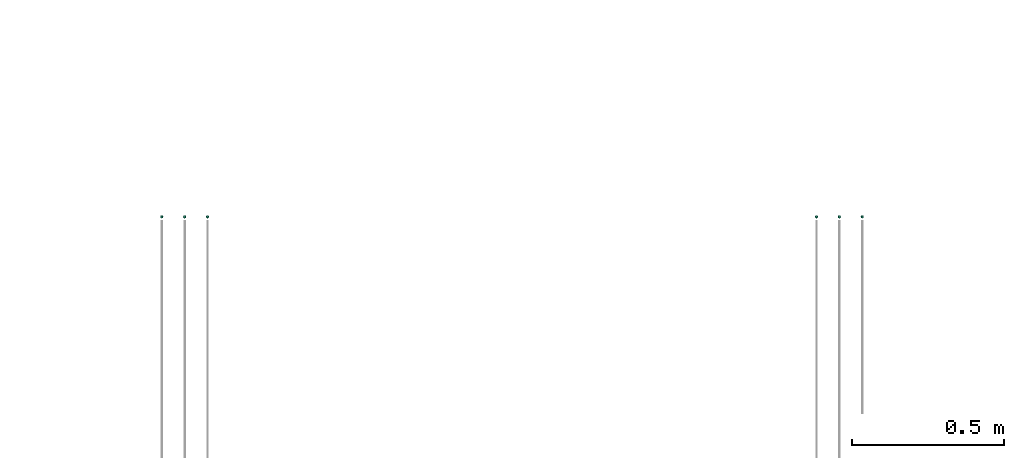
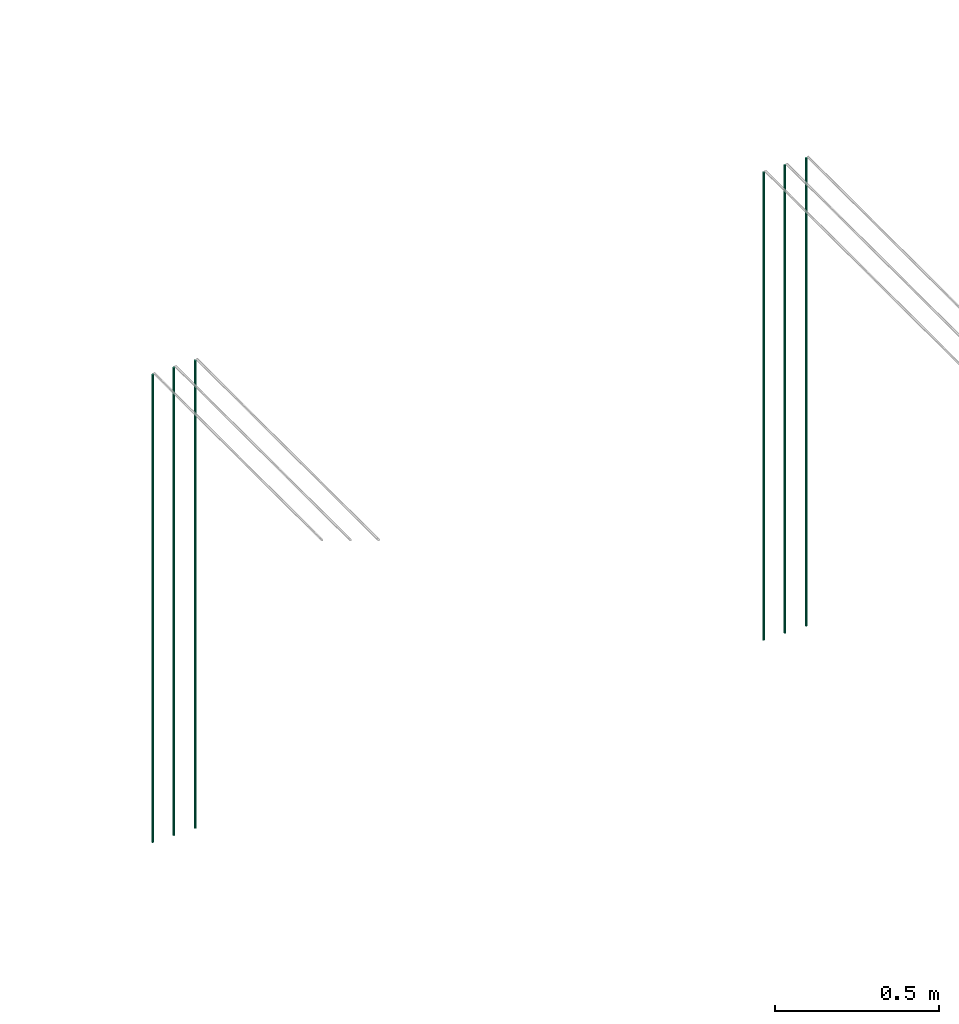
# One storey, part 5 of 89: 6 flow segments.
"""IFC2X3 building model written with IfcOpenShell, lengths in millimetres."""

from ifc_helpers import new_model, entity, si_unit, converted_unit, derived_unit, direction, frame, frame_2d, origin, origin_2d_with_axis, place, context, subcontext, project, spatial, circle, extrude, type_object, element, save


model = new_model("IFC2X3")

# Units and contexts
model_context = context("Model", 3, precision=0.01, world=origin(), true_north=direction((6.12303176911189e-17, 1.0)))
body_context = subcontext(model_context, "Body", "Model", "MODEL_VIEW")
ifc_project = project(units=[si_unit("LENGTHUNIT", "METRE", prefix="MILLI"), si_unit("AREAUNIT", "SQUARE_METRE"), si_unit("VOLUMEUNIT", "CUBIC_METRE"), converted_unit("PLANEANGLEUNIT", "DEGREE", entity("IfcRatioMeasure", 0.0174532925199433), si_unit("PLANEANGLEUNIT", "RADIAN"), dimensions=[0, 0, 0, 0, 0, 0, 0]), si_unit("MASSUNIT", "GRAM", prefix="KILO"), derived_unit("MASSDENSITYUNIT", [(si_unit("MASSUNIT", "GRAM", prefix="KILO"), 1), (si_unit("LENGTHUNIT", "METRE"), -3)]), derived_unit("MOMENTOFINERTIAUNIT", [(si_unit("LENGTHUNIT", "METRE"), 4)]), si_unit("TIMEUNIT", "SECOND"), si_unit("FREQUENCYUNIT", "HERTZ"), si_unit("THERMODYNAMICTEMPERATUREUNIT", "DEGREE_CELSIUS"), derived_unit("THERMALTRANSMITTANCEUNIT", [(si_unit("MASSUNIT", "GRAM", prefix="KILO"), 1), (si_unit("THERMODYNAMICTEMPERATUREUNIT", "KELVIN"), -1), (si_unit("TIMEUNIT", "SECOND"), -3)]), derived_unit("VOLUMETRICFLOWRATEUNIT", [(si_unit("LENGTHUNIT", "METRE"), 3), (si_unit("TIMEUNIT", "SECOND"), -1)]), derived_unit("MASSFLOWRATEUNIT", [(si_unit("MASSUNIT", "GRAM", prefix="KILO"), 1), (si_unit("TIMEUNIT", "SECOND"), -1)]), derived_unit("ROTATIONALFREQUENCYUNIT", [(si_unit("TIMEUNIT", "SECOND"), -1)]), si_unit("ELECTRICCURRENTUNIT", "AMPERE"), si_unit("ELECTRICVOLTAGEUNIT", "VOLT"), si_unit("POWERUNIT", "WATT"), si_unit("FORCEUNIT", "NEWTON", prefix="KILO"), si_unit("ILLUMINANCEUNIT", "LUX"), si_unit("LUMINOUSFLUXUNIT", "LUMEN"), si_unit("LUMINOUSINTENSITYUNIT", "CANDELA"), derived_unit("USERDEFINED", [(si_unit("MASSUNIT", "GRAM", prefix="KILO"), -1), (si_unit("LENGTHUNIT", "METRE"), -2), (si_unit("TIMEUNIT", "SECOND"), 3), (si_unit("LUMINOUSFLUXUNIT", "LUMEN"), 1)]), derived_unit("LINEARVELOCITYUNIT", [(si_unit("LENGTHUNIT", "METRE"), 1), (si_unit("TIMEUNIT", "SECOND"), -1)]), si_unit("PRESSUREUNIT", "PASCAL"), derived_unit("USERDEFINED", [(si_unit("LENGTHUNIT", "METRE"), -2), (si_unit("MASSUNIT", "GRAM", prefix="KILO"), 1), (si_unit("TIMEUNIT", "SECOND"), -2)]), derived_unit("LINEARFORCEUNIT", [(si_unit("MASSUNIT", "GRAM", prefix="KILO"), 1), (si_unit("LENGTHUNIT", "METRE"), 1), (si_unit("TIMEUNIT", "SECOND"), -2), (si_unit("LENGTHUNIT", "METRE"), -1)]), derived_unit("PLANARFORCEUNIT", [(si_unit("MASSUNIT", "GRAM", prefix="KILO"), 1), (si_unit("LENGTHUNIT", "METRE"), 1), (si_unit("TIMEUNIT", "SECOND"), -2), (si_unit("LENGTHUNIT", "METRE"), -2)])], contexts=[model_context])

# Site, building, storey
site_placement = place(None, frame((0.0, -0.00077364408347762, 0.0)))
site = spatial("IfcSite", under=ifc_project, at=site_placement, CompositionType="ELEMENT")
building_placement = place(site_placement, origin())
building = spatial("IfcBuilding", under=site, at=building_placement, CompositionType="ELEMENT")
storey_placement = place(building_placement, frame((0.0, 0.0, 24000.0)))
storey = spatial("IfcBuildingStorey", under=building, at=storey_placement, CompositionType="ELEMENT", Elevation=24000.0)

# Flow segments
pipe_segment_type = type_object("IfcPipeSegmentType", PredefinedType="NOTDEFINED")
flow_segment_1_placement = place(storey_placement, frame((44870.5982478344, 8394.39395908997, 1400.0)))
element("IfcFlowSegment", 1, at=flow_segment_1_placement, inside=storey, type_object=pipe_segment_type, context=body_context, shape_type="SweptSolid", body=[
    extrude(circle(Radius=4.0, at=frame_2d((0.0, 1.08286712929839e-12), x_axis=(1.0, 0.0))), frame((5.59527223591499, 5.59527223591499, 0.0)), (0.0, 0.0, 1.0), 1740.0),
])
for number, where in (
    (2, (45020.5981151137, 8394.39395908997, 1400.0)),
    (3, (44945.5981151137, 8394.39395908997, 1400.0)),
):
    element("IfcFlowSegment", number, at=place(storey_placement, frame(where)), inside=storey, type_object=pipe_segment_type, context=body_context, shape_type="SweptSolid", body=[
        extrude(circle(Radius=4.0, at=frame_2d((0.0, -1.08286712929839e-12), x_axis=(1.0, 0.0))), frame((5.59527223591499, 5.59527223591716, 0.0)), (0.0, 0.0, 1.0), 1740.0),
    ])
flow_segment_2_placement = place(storey_placement, frame((47020.5982478344, 8394.39395908997, 1400.0)))
element("IfcFlowSegment", 4, at=flow_segment_2_placement, inside=storey, type_object=pipe_segment_type, context=body_context, shape_type="SweptSolid", body=[
    extrude(circle(Radius=4.0, at=origin_2d_with_axis()), frame((5.59527223591499, 5.59527223591607, 0.0)), (0.0, 0.0, 1.0), 1740.0),
])
for number, where in (
    (5, (47170.5981151137, 8394.39395908996, 1400.0)),
    (6, (47095.5981151137, 8394.39395908996, 1400.0)),
):
    element("IfcFlowSegment", number, at=place(storey_placement, frame(where)), inside=storey, type_object=pipe_segment_type, context=body_context, shape_type="SweptSolid", body=[
        extrude(circle(Radius=4.0, at=frame_2d((0.0, 1.08286712929839e-12), x_axis=(1.0, 0.0))), frame((5.59527223591499, 5.59527223591499, 0.0)), (0.0, 0.0, 1.0), 1740.0),
    ])

save(model, "model.ifc")
